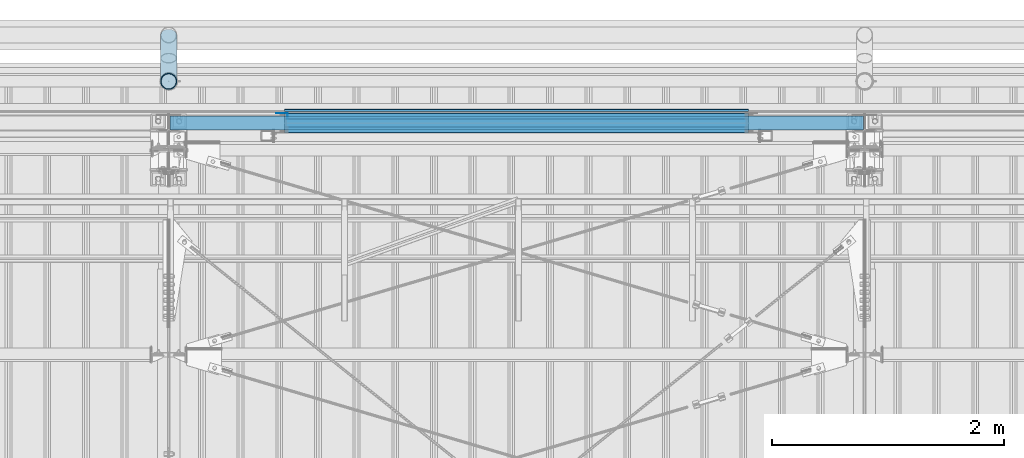
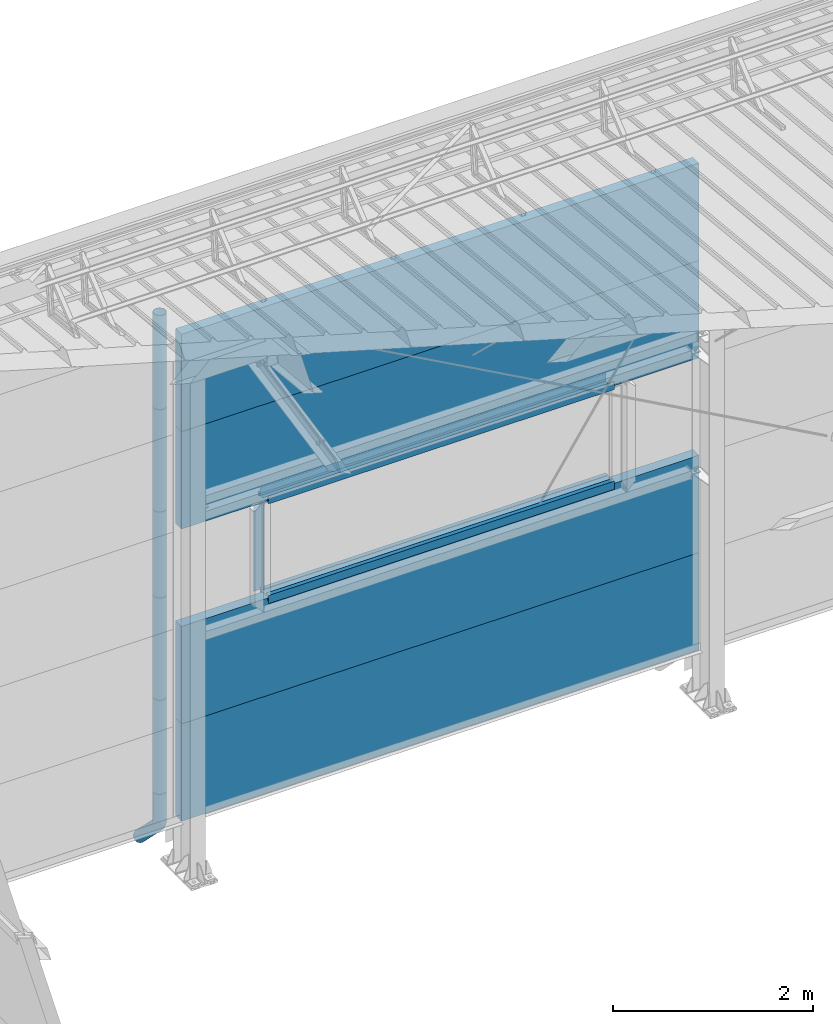
# One storey, part 53 of 709: 18 beams, 18 elements without a shape of their own.
"""IFC4 building model written with IfcOpenShell, lengths in millimetres."""

from ifc_helpers import new_model, entity, si_unit, direction, frame, origin_with_axes, place, context, subcontext, project, spatial, line, indexed_curve, outline, extrude, material, element, aggregate, save


model = new_model("IFC4")

# Units and contexts
model_context = context("Model", 3, precision=0.2, world=origin_with_axes(), true_north=direction((0.0, 1.0)))
body_context = subcontext(model_context, "Body", "Model", "MODEL_VIEW")
ifc_project = project(units=[si_unit("LENGTHUNIT", "METRE", prefix="MILLI"), si_unit("AREAUNIT", "SQUARE_METRE"), si_unit("VOLUMEUNIT", "CUBIC_METRE"), si_unit("MASSUNIT", "GRAM", prefix="KILO"), si_unit("TIMEUNIT", "SECOND"), si_unit("PLANEANGLEUNIT", "RADIAN"), si_unit("SOLIDANGLEUNIT", "STERADIAN"), si_unit("THERMODYNAMICTEMPERATUREUNIT", "DEGREE_CELSIUS"), si_unit("LUMINOUSINTENSITYUNIT", "LUMEN")], contexts=[model_context])

# Site, building, storey
site_placement = place(None, origin_with_axes())
site = spatial("IfcSite", under=ifc_project, at=site_placement, CompositionType="ELEMENT")
building_placement = place(site_placement, origin_with_axes())
building = spatial("IfcBuilding", under=site, at=building_placement, Name="Undefined", CompositionType="ELEMENT")
storey_placement = place(building_placement, origin_with_axes())
storey = spatial("IfcBuildingStorey", under=building, at=storey_placement, Name="Undefined", CompositionType="ELEMENT", Elevation=0.0)

# Assembly, beam
assembly_1_placement = place(storey_placement, frame((4010.0, 22060.0, 895.0), z_axis=(0.0, 0.0, -1.0), x_axis=(1.0, 0.0, 0.0)))
assembly_1 = element("IfcElementAssembly", 1, at=assembly_1_placement, inside=storey)
ifc_material_1 = material(Name="Insulation", Category="Insulation")
beam_1_placement = place(assembly_1_placement, origin_with_axes())
beam_1 = element("IfcBeam", 2, at=beam_1_placement, material=ifc_material_1, ObjectType="P-107", context=body_context, shape_type="SolidModel", body=[
    extrude(outline(indexed_curve([(-595.0, -60.0), (595.0, -60.0), (595.0, 60.0), (-595.0, 60.0)], segments=[line(1, 2, 3, 4, 1)])), frame((0.0, 0.0, 0.0), z_axis=(-1.0, 0.0, 0.0), x_axis=(0.0, 0.0, 1.0)), (0.0, 0.0, -1.0), 5980.0),
])
aggregate(assembly_1, [beam_1])

assembly_2_placement = place(storey_placement, frame((4010.0, 22060.0, 2085.0), z_axis=(0.0, 0.0, -1.0), x_axis=(1.0, 0.0, 0.0)))
assembly_2 = element("IfcElementAssembly", 3, at=assembly_2_placement, inside=storey)
beam_2_placement = place(assembly_2_placement, origin_with_axes())
beam_2 = element("IfcBeam", 4, at=beam_2_placement, material=ifc_material_1, ObjectType="P-107", context=body_context, shape_type="SolidModel", body=[
    extrude(outline(indexed_curve([(-595.0, -60.0), (595.0, -60.0), (595.0, 60.0), (-595.0, 60.0)], segments=[line(1, 2, 3, 4, 1)])), frame((0.0, 0.0, 0.0), z_axis=(-1.0, 0.0, 0.0), x_axis=(0.0, 0.0, 1.0)), (0.0, 0.0, -1.0), 5980.0),
])
aggregate(assembly_2, [beam_2])

assembly_3_placement = place(storey_placement, frame((4010.0, 22060.0, 4465.0), z_axis=(0.0, 0.0, -1.0), x_axis=(1.0, 0.0, 0.0)))
assembly_3 = element("IfcElementAssembly", 5, at=assembly_3_placement, inside=storey)
beam_3_placement = place(assembly_3_placement, origin_with_axes())
beam_3 = element("IfcBeam", 6, at=beam_3_placement, material=ifc_material_1, ObjectType="P-107", context=body_context, shape_type="SolidModel", body=[
    extrude(outline(indexed_curve([(-595.0, -60.0), (595.0, -60.0), (595.0, 60.0), (-595.0, 60.0)], segments=[line(1, 2, 3, 4, 1)])), frame((0.0, 0.0, 0.0), z_axis=(-1.0, 0.0, 0.0), x_axis=(0.0, 0.0, 1.0)), (0.0, 0.0, -1.0), 5980.0),
])
aggregate(assembly_3, [beam_3])

assembly_4_placement = place(storey_placement, frame((4010.0, 22060.0, 5655.0), z_axis=(0.0, 0.0, -1.0), x_axis=(1.0, 0.0, 0.0)))
assembly_4 = element("IfcElementAssembly", 7, at=assembly_4_placement, inside=storey)
beam_4_placement = place(assembly_4_placement, origin_with_axes())
beam_4 = element("IfcBeam", 8, at=beam_4_placement, material=ifc_material_1, ObjectType="P-107", context=body_context, shape_type="SolidModel", body=[
    extrude(outline(indexed_curve([(-595.0, -60.0), (595.0, -60.0), (595.0, 60.0), (-595.0, 60.0)], segments=[line(1, 2, 3, 4, 1)])), frame((0.0, 0.0, 0.0), z_axis=(-1.0, 0.0, 0.0), x_axis=(0.0, 0.0, 1.0)), (0.0, 0.0, -1.0), 5980.0),
])
aggregate(assembly_4, [beam_4])

assembly_5_placement = place(storey_placement, frame((9000.0, 22001.0, 2725.0), z_axis=(0.0, -1.0, 0.0), x_axis=(-1.0, 0.0, 0.0)))
assembly_5 = element("IfcElementAssembly", 9, at=assembly_5_placement, inside=storey)
ifc_material_2 = material(Name="Steel_Undefined", Category="STEEL")
beam_5_placement = place(assembly_5_placement, origin_with_axes())
beam_5 = element("IfcBeam", 10, at=beam_5_placement, material=ifc_material_2, context=body_context, shape_type="SolidModel", body=[
    extrude(outline(indexed_curve([(-25.0, -1.0), (25.0, -1.0), (25.0, 99.0), (23.0, 99.0), (23.0, 1.0), (-25.0, 1.0)], segments=[line(1, 2, 3, 4, 5, 6, 1)])), frame((0.0, 0.0, 0.0), z_axis=(-1.0, 0.0, 0.0), x_axis=(0.0, 0.0, 1.0)), (0.0, 0.0, -1.0), 4000.0),
])
aggregate(assembly_5, [beam_5])

assembly_6_placement = place(storey_placement, frame((9000.0, 22060.0, 2680.0), z_axis=(0.0, 1.0, 0.0), x_axis=(-1.0, 0.0, 0.0)))
assembly_6 = element("IfcElementAssembly", 11, at=assembly_6_placement, inside=storey)
beam_6_placement = place(assembly_6_placement, origin_with_axes())
beam_6 = element("IfcBeam", 12, at=beam_6_placement, material=ifc_material_2, context=body_context, shape_type="SolidModel", body=[
    extrude(outline(indexed_curve([(-70.0, -25.0), (-68.0, -25.0), (-68.0, 23.0), (68.0, 23.0), (68.0, -25.0), (70.0, -25.0), (70.0, 25.0), (-70.0, 25.0)], segments=[line(1, 2, 3, 4, 5, 6, 7, 8, 1)])), frame((0.0, 0.0, 0.0), z_axis=(-1.0, 0.0, 0.0), x_axis=(0.0, 0.0, 1.0)), (0.0, 0.0, -1.0), 4000.0),
])
aggregate(assembly_6, [beam_6])

assembly_7_placement = place(storey_placement, frame((5000.0, 22121.0, 2725.0), z_axis=(0.0, 1.0, 0.0), x_axis=(1.0, 0.0, 0.0)))
assembly_7 = element("IfcElementAssembly", 13, at=assembly_7_placement, inside=storey)
beam_7_placement = place(assembly_7_placement, origin_with_axes())
beam_7 = element("IfcBeam", 14, at=beam_7_placement, material=ifc_material_2, context=body_context, shape_type="SolidModel", body=[
    extrude(outline(indexed_curve([(-25.0, -1.0), (25.0, -1.0), (25.0, 99.0), (23.0, 99.0), (23.0, 1.0), (-25.0, 1.0)], segments=[line(1, 2, 3, 4, 5, 6, 1)])), frame((0.0, 0.0, 0.0), z_axis=(-1.0, 0.0, 0.0), x_axis=(0.0, 0.0, 1.0)), (0.0, 0.0, -1.0), 4000.0),
])
aggregate(assembly_7, [beam_7])

assembly_8_placement = place(storey_placement, frame((5000.0, 22001.0, 3845.0), z_axis=(0.0, -1.0, 0.0), x_axis=(1.0, 0.0, 0.0)))
assembly_8 = element("IfcElementAssembly", 15, at=assembly_8_placement, inside=storey)
beam_8_placement = place(assembly_8_placement, origin_with_axes())
beam_8 = element("IfcBeam", 16, at=beam_8_placement, material=ifc_material_2, context=body_context, shape_type="SolidModel", body=[
    extrude(outline(indexed_curve([(-25.0, -1.0), (25.0, -1.0), (25.0, 99.0), (23.0, 99.0), (23.0, 1.0), (-25.0, 1.0)], segments=[line(1, 2, 3, 4, 5, 6, 1)])), frame((0.0, 0.0, 0.0), z_axis=(-1.0, 0.0, 0.0), x_axis=(0.0, 0.0, 1.0)), (0.0, 0.0, -1.0), 4000.0),
])
aggregate(assembly_8, [beam_8])

assembly_9_placement = place(storey_placement, frame((9000.0, 22060.0, 3890.0), z_axis=(0.0, -1.0, 0.0), x_axis=(-1.0, 0.0, 0.0)))
assembly_9 = element("IfcElementAssembly", 17, at=assembly_9_placement, inside=storey)
beam_9_placement = place(assembly_9_placement, origin_with_axes())
beam_9 = element("IfcBeam", 18, at=beam_9_placement, material=ifc_material_2, context=body_context, shape_type="SolidModel", body=[
    extrude(outline(indexed_curve([(-70.0, -25.0), (-68.0, -25.0), (-68.0, 23.0), (68.0, 23.0), (68.0, -25.0), (70.0, -25.0), (70.0, 25.0), (-70.0, 25.0)], segments=[line(1, 2, 3, 4, 5, 6, 7, 8, 1)])), frame((0.0, 0.0, 0.0), z_axis=(-1.0, 0.0, 0.0), x_axis=(0.0, 0.0, 1.0)), (0.0, 0.0, -1.0), 4000.0),
])
aggregate(assembly_9, [beam_9])

assembly_10_placement = place(storey_placement, frame((9000.0, 22121.0, 3845.0), z_axis=(0.0, 1.0, 0.0), x_axis=(-1.0, 0.0, 0.0)))
assembly_10 = element("IfcElementAssembly", 19, at=assembly_10_placement, inside=storey)
beam_10_placement = place(assembly_10_placement, origin_with_axes())
beam_10 = element("IfcBeam", 20, at=beam_10_placement, material=ifc_material_2, context=body_context, shape_type="SolidModel", body=[
    extrude(outline(indexed_curve([(-25.0, -1.0), (25.0, -1.0), (25.0, 99.0), (23.0, 99.0), (23.0, 1.0), (-25.0, 1.0)], segments=[line(1, 2, 3, 4, 5, 6, 1)])), frame((0.0, 0.0, 0.0), z_axis=(-1.0, 0.0, 0.0), x_axis=(0.0, 0.0, 1.0)), (0.0, 0.0, -1.0), 4000.0),
])
aggregate(assembly_10, [beam_10])

assembly_11_placement = place(storey_placement, frame((9000.0, 22171.0, 3830.0), z_axis=(0.0, 1.0, 0.0), x_axis=(-1.0, 0.0, 0.0)))
assembly_11 = element("IfcElementAssembly", 21, at=assembly_11_placement, inside=storey)
beam_11_placement = place(assembly_11_placement, origin_with_axes())
beam_11 = element("IfcBeam", 22, at=beam_11_placement, material=ifc_material_2, context=body_context, shape_type="SolidModel", body=[
    extrude(outline(indexed_curve([(-10.0, -1.0), (10.0, -1.0), (10.0, 49.0), (8.0, 49.0), (8.0, 1.0), (-10.0, 1.0)], segments=[line(1, 2, 3, 4, 5, 6, 1)])), frame((0.0, 0.0, 0.0), z_axis=(-1.0, 0.0, 0.0), x_axis=(0.0, 0.0, 1.0)), (0.0, 0.0, -1.0), 4000.0),
])
aggregate(assembly_11, [beam_11])

assembly_12_placement = place(storey_placement, frame((5025.0, 22121.0, 3870.0), z_axis=(0.0, 1.0, 0.0), x_axis=(0.0, 0.0, -1.0)))
assembly_12 = element("IfcElementAssembly", 23, at=assembly_12_placement, inside=storey)
beam_12_placement = place(assembly_12_placement, origin_with_axes())
beam_12 = element("IfcBeam", 24, at=beam_12_placement, material=ifc_material_2, context=body_context, shape_type="SolidModel", body=[
    extrude(outline(indexed_curve([(-25.0, -1.0), (25.0, -1.0), (25.0, 99.0), (23.0, 99.0), (23.0, 1.0), (-25.0, 1.0)], segments=[line(1, 2, 3, 4, 5, 6, 1)])), frame((0.0, 0.0, 0.0), z_axis=(-1.0, 0.0, 0.0), x_axis=(0.0, 0.0, 1.0)), (0.0, 0.0, -1.0), 1170.0),
])
aggregate(assembly_12, [beam_12])

assembly_13_placement = place(storey_placement, frame((4000.0, 22420.0, 6276.92297), z_axis=(0.0, -1.0, 0.0), x_axis=(0.0, 0.0, -1.0)))
assembly_13 = element("IfcElementAssembly", 25, at=assembly_13_placement, inside=storey)
beam_13_placement = place(assembly_13_placement, origin_with_axes())
beam_13 = element("IfcBeam", 26, at=beam_13_placement, material=ifc_material_2, ObjectType="614", context=body_context, shape_type="SolidModel", body=[
    extrude(outline(indexed_curve([(70.0, 0.0), (69.61653, 7.31699), (68.47033, 14.55382), (66.57396, 21.63119), (63.94818, 28.47157), (60.62178, 35.0), (56.63119, 41.14497), (52.02014, 46.83914), (46.83914, 52.02014), (41.14497, 56.63119), (35.0, 60.62178), (28.47157, 63.94818), (21.63119, 66.57396), (14.55382, 68.47033), (7.31699, 69.61653), (0.0, 70.0), (-7.31699, 69.61653), (-14.55382, 68.47033), (-21.63119, 66.57396), (-28.47157, 63.94818), (-35.0, 60.62178), (-41.14497, 56.63119), (-46.83914, 52.02014), (-52.02014, 46.83914), (-56.63119, 41.14497), (-60.62178, 35.0), (-63.94818, 28.47157), (-66.57396, 21.63119), (-68.47033, 14.55382), (-69.61653, 7.31699), (-70.0, 0.0), (-69.61653, -7.31699), (-68.47033, -14.55382), (-66.57396, -21.63119), (-63.94818, -28.47157), (-60.62178, -35.0), (-56.63119, -41.14497), (-52.02014, -46.83914), (-46.83914, -52.02014), (-41.14497, -56.63119), (-35.0, -60.62178), (-28.47157, -63.94818), (-21.63119, -66.57396), (-14.55382, -68.47033), (-7.31699, -69.61653), (0.0, -70.0), (7.31699, -69.61653), (14.55382, -68.47033), (21.63119, -66.57396), (28.47157, -63.94818), (35.0, -60.62178), (41.14497, -56.63119), (46.83914, -52.02014), (52.02014, -46.83914), (56.63119, -41.14497), (60.62178, -35.0), (63.94818, -28.47157), (66.57396, -21.63119), (68.47033, -14.55382), (69.61653, -7.31699)], segments=[line(1, 2, 3, 4, 5, 6, 7, 8, 9, 10, 11, 12, 13, 14, 15, 16, 17, 18, 19, 20, 21, 22, 23, 24, 25, 26, 27, 28, 29, 30, 31, 32, 33, 34, 35, 36, 37, 38, 39, 40, 41, 42, 43, 44, 45, 46, 47, 48, 49, 50, 51, 52, 53, 54, 55, 56, 57, 58, 59, 60, 1)]), holes=[indexed_curve([(65.0, 0.0), (64.64392, -6.79435), (63.57959, -13.51426), (61.81867, -20.0861), (59.38045, -26.43788), (56.29165, -32.5), (52.5861, -38.20604), (48.30441, -43.49349), (43.49349, -48.30441), (38.20604, -52.5861), (32.5, -56.29165), (26.43788, -59.38045), (20.0861, -61.81867), (13.51426, -63.57959), (6.79435, -64.64392), (0.0, -65.0), (-6.79435, -64.64392), (-13.51426, -63.57959), (-20.0861, -61.81867), (-26.43788, -59.38045), (-32.5, -56.29165), (-38.20604, -52.5861), (-43.49349, -48.30441), (-48.30441, -43.49349), (-52.5861, -38.20604), (-56.29165, -32.5), (-59.38045, -26.43788), (-61.81867, -20.0861), (-63.57959, -13.51426), (-64.64392, -6.79435), (-65.0, 0.0), (-64.64392, 6.79435), (-63.57959, 13.51426), (-61.81867, 20.0861), (-59.38045, 26.43788), (-56.29165, 32.5), (-52.5861, 38.20604), (-48.30441, 43.49349), (-43.49349, 48.30441), (-38.20604, 52.5861), (-32.5, 56.29165), (-26.43788, 59.38045), (-20.0861, 61.81867), (-13.51426, 63.57959), (-6.79435, 64.64392), (0.0, 65.0), (6.79435, 64.64392), (13.51426, 63.57959), (20.0861, 61.81867), (26.43788, 59.38045), (32.5, 56.29165), (38.20604, 52.5861), (43.49349, 48.30441), (48.30441, 43.49349), (52.5861, 38.20604), (56.29165, 32.5), (59.38045, 26.43788), (61.81867, 20.0861), (63.57959, 13.51426), (64.64392, 6.79435)], segments=[line(1, 2, 3, 4, 5, 6, 7, 8, 9, 10, 11, 12, 13, 14, 15, 16, 17, 18, 19, 20, 21, 22, 23, 24, 25, 26, 27, 28, 29, 30, 31, 32, 33, 34, 35, 36, 37, 38, 39, 40, 41, 42, 43, 44, 45, 46, 47, 48, 49, 50, 51, 52, 53, 54, 55, 56, 57, 58, 59, 60, 1)])]), frame((0.0, 0.0, 0.0), z_axis=(-1.0, 0.0, 0.0), x_axis=(0.0, 0.0, 1.0)), (0.0, 0.0, -1.0), 1250.0),
])
aggregate(assembly_13, [beam_13])

assembly_14_placement = place(storey_placement, frame((4000.0, 22420.0, 5126.92297), z_axis=(0.0, -1.0, 0.0), x_axis=(0.0, 0.0, -1.0)))
assembly_14 = element("IfcElementAssembly", 27, at=assembly_14_placement, inside=storey)
beam_14_placement = place(assembly_14_placement, origin_with_axes())
beam_14 = element("IfcBeam", 28, at=beam_14_placement, material=ifc_material_2, ObjectType="614", context=body_context, shape_type="SolidModel", body=[
    extrude(outline(indexed_curve([(70.0, 0.0), (69.61653, 7.31699), (68.47033, 14.55382), (66.57396, 21.63119), (63.94818, 28.47157), (60.62178, 35.0), (56.63119, 41.14497), (52.02014, 46.83914), (46.83914, 52.02014), (41.14497, 56.63119), (35.0, 60.62178), (28.47157, 63.94818), (21.63119, 66.57396), (14.55382, 68.47033), (7.31699, 69.61653), (0.0, 70.0), (-7.31699, 69.61653), (-14.55382, 68.47033), (-21.63119, 66.57396), (-28.47157, 63.94818), (-35.0, 60.62178), (-41.14497, 56.63119), (-46.83914, 52.02014), (-52.02014, 46.83914), (-56.63119, 41.14497), (-60.62178, 35.0), (-63.94818, 28.47157), (-66.57396, 21.63119), (-68.47033, 14.55382), (-69.61653, 7.31699), (-70.0, 0.0), (-69.61653, -7.31699), (-68.47033, -14.55382), (-66.57396, -21.63119), (-63.94818, -28.47157), (-60.62178, -35.0), (-56.63119, -41.14497), (-52.02014, -46.83914), (-46.83914, -52.02014), (-41.14497, -56.63119), (-35.0, -60.62178), (-28.47157, -63.94818), (-21.63119, -66.57396), (-14.55382, -68.47033), (-7.31699, -69.61653), (0.0, -70.0), (7.31699, -69.61653), (14.55382, -68.47033), (21.63119, -66.57396), (28.47157, -63.94818), (35.0, -60.62178), (41.14497, -56.63119), (46.83914, -52.02014), (52.02014, -46.83914), (56.63119, -41.14497), (60.62178, -35.0), (63.94818, -28.47157), (66.57396, -21.63119), (68.47033, -14.55382), (69.61653, -7.31699)], segments=[line(1, 2, 3, 4, 5, 6, 7, 8, 9, 10, 11, 12, 13, 14, 15, 16, 17, 18, 19, 20, 21, 22, 23, 24, 25, 26, 27, 28, 29, 30, 31, 32, 33, 34, 35, 36, 37, 38, 39, 40, 41, 42, 43, 44, 45, 46, 47, 48, 49, 50, 51, 52, 53, 54, 55, 56, 57, 58, 59, 60, 1)]), holes=[indexed_curve([(65.0, 0.0), (64.64392, -6.79435), (63.57959, -13.51426), (61.81867, -20.0861), (59.38045, -26.43788), (56.29165, -32.5), (52.5861, -38.20604), (48.30441, -43.49349), (43.49349, -48.30441), (38.20604, -52.5861), (32.5, -56.29165), (26.43788, -59.38045), (20.0861, -61.81867), (13.51426, -63.57959), (6.79435, -64.64392), (0.0, -65.0), (-6.79435, -64.64392), (-13.51426, -63.57959), (-20.0861, -61.81867), (-26.43788, -59.38045), (-32.5, -56.29165), (-38.20604, -52.5861), (-43.49349, -48.30441), (-48.30441, -43.49349), (-52.5861, -38.20604), (-56.29165, -32.5), (-59.38045, -26.43788), (-61.81867, -20.0861), (-63.57959, -13.51426), (-64.64392, -6.79435), (-65.0, 0.0), (-64.64392, 6.79435), (-63.57959, 13.51426), (-61.81867, 20.0861), (-59.38045, 26.43788), (-56.29165, 32.5), (-52.5861, 38.20604), (-48.30441, 43.49349), (-43.49349, 48.30441), (-38.20604, 52.5861), (-32.5, 56.29165), (-26.43788, 59.38045), (-20.0861, 61.81867), (-13.51426, 63.57959), (-6.79435, 64.64392), (0.0, 65.0), (6.79435, 64.64392), (13.51426, 63.57959), (20.0861, 61.81867), (26.43788, 59.38045), (32.5, 56.29165), (38.20604, 52.5861), (43.49349, 48.30441), (48.30441, 43.49349), (52.5861, 38.20604), (56.29165, 32.5), (59.38045, 26.43788), (61.81867, 20.0861), (63.57959, 13.51426), (64.64392, 6.79435)], segments=[line(1, 2, 3, 4, 5, 6, 7, 8, 9, 10, 11, 12, 13, 14, 15, 16, 17, 18, 19, 20, 21, 22, 23, 24, 25, 26, 27, 28, 29, 30, 31, 32, 33, 34, 35, 36, 37, 38, 39, 40, 41, 42, 43, 44, 45, 46, 47, 48, 49, 50, 51, 52, 53, 54, 55, 56, 57, 58, 59, 60, 1)])]), frame((0.0, 0.0, 0.0), z_axis=(-1.0, 0.0, 0.0), x_axis=(0.0, 0.0, 1.0)), (0.0, 0.0, -1.0), 1250.0),
])
aggregate(assembly_14, [beam_14])

assembly_15_placement = place(storey_placement, frame((4000.0, 22420.0, 3976.92297), z_axis=(0.0, -1.0, 0.0), x_axis=(0.0, 0.0, -1.0)))
assembly_15 = element("IfcElementAssembly", 29, at=assembly_15_placement, inside=storey)
beam_15_placement = place(assembly_15_placement, origin_with_axes())
beam_15 = element("IfcBeam", 30, at=beam_15_placement, material=ifc_material_2, ObjectType="614", context=body_context, shape_type="SolidModel", body=[
    extrude(outline(indexed_curve([(70.0, 0.0), (69.61653, 7.31699), (68.47033, 14.55382), (66.57396, 21.63119), (63.94818, 28.47157), (60.62178, 35.0), (56.63119, 41.14497), (52.02014, 46.83914), (46.83914, 52.02014), (41.14497, 56.63119), (35.0, 60.62178), (28.47157, 63.94818), (21.63119, 66.57396), (14.55382, 68.47033), (7.31699, 69.61653), (0.0, 70.0), (-7.31699, 69.61653), (-14.55382, 68.47033), (-21.63119, 66.57396), (-28.47157, 63.94818), (-35.0, 60.62178), (-41.14497, 56.63119), (-46.83914, 52.02014), (-52.02014, 46.83914), (-56.63119, 41.14497), (-60.62178, 35.0), (-63.94818, 28.47157), (-66.57396, 21.63119), (-68.47033, 14.55382), (-69.61653, 7.31699), (-70.0, 0.0), (-69.61653, -7.31699), (-68.47033, -14.55382), (-66.57396, -21.63119), (-63.94818, -28.47157), (-60.62178, -35.0), (-56.63119, -41.14497), (-52.02014, -46.83914), (-46.83914, -52.02014), (-41.14497, -56.63119), (-35.0, -60.62178), (-28.47157, -63.94818), (-21.63119, -66.57396), (-14.55382, -68.47033), (-7.31699, -69.61653), (0.0, -70.0), (7.31699, -69.61653), (14.55382, -68.47033), (21.63119, -66.57396), (28.47157, -63.94818), (35.0, -60.62178), (41.14497, -56.63119), (46.83914, -52.02014), (52.02014, -46.83914), (56.63119, -41.14497), (60.62178, -35.0), (63.94818, -28.47157), (66.57396, -21.63119), (68.47033, -14.55382), (69.61653, -7.31699)], segments=[line(1, 2, 3, 4, 5, 6, 7, 8, 9, 10, 11, 12, 13, 14, 15, 16, 17, 18, 19, 20, 21, 22, 23, 24, 25, 26, 27, 28, 29, 30, 31, 32, 33, 34, 35, 36, 37, 38, 39, 40, 41, 42, 43, 44, 45, 46, 47, 48, 49, 50, 51, 52, 53, 54, 55, 56, 57, 58, 59, 60, 1)]), holes=[indexed_curve([(65.0, 0.0), (64.64392, -6.79435), (63.57959, -13.51426), (61.81867, -20.0861), (59.38045, -26.43788), (56.29165, -32.5), (52.5861, -38.20604), (48.30441, -43.49349), (43.49349, -48.30441), (38.20604, -52.5861), (32.5, -56.29165), (26.43788, -59.38045), (20.0861, -61.81867), (13.51426, -63.57959), (6.79435, -64.64392), (0.0, -65.0), (-6.79435, -64.64392), (-13.51426, -63.57959), (-20.0861, -61.81867), (-26.43788, -59.38045), (-32.5, -56.29165), (-38.20604, -52.5861), (-43.49349, -48.30441), (-48.30441, -43.49349), (-52.5861, -38.20604), (-56.29165, -32.5), (-59.38045, -26.43788), (-61.81867, -20.0861), (-63.57959, -13.51426), (-64.64392, -6.79435), (-65.0, 0.0), (-64.64392, 6.79435), (-63.57959, 13.51426), (-61.81867, 20.0861), (-59.38045, 26.43788), (-56.29165, 32.5), (-52.5861, 38.20604), (-48.30441, 43.49349), (-43.49349, 48.30441), (-38.20604, 52.5861), (-32.5, 56.29165), (-26.43788, 59.38045), (-20.0861, 61.81867), (-13.51426, 63.57959), (-6.79435, 64.64392), (0.0, 65.0), (6.79435, 64.64392), (13.51426, 63.57959), (20.0861, 61.81867), (26.43788, 59.38045), (32.5, 56.29165), (38.20604, 52.5861), (43.49349, 48.30441), (48.30441, 43.49349), (52.5861, 38.20604), (56.29165, 32.5), (59.38045, 26.43788), (61.81867, 20.0861), (63.57959, 13.51426), (64.64392, 6.79435)], segments=[line(1, 2, 3, 4, 5, 6, 7, 8, 9, 10, 11, 12, 13, 14, 15, 16, 17, 18, 19, 20, 21, 22, 23, 24, 25, 26, 27, 28, 29, 30, 31, 32, 33, 34, 35, 36, 37, 38, 39, 40, 41, 42, 43, 44, 45, 46, 47, 48, 49, 50, 51, 52, 53, 54, 55, 56, 57, 58, 59, 60, 1)])]), frame((0.0, 0.0, 0.0), z_axis=(-1.0, 0.0, 0.0), x_axis=(0.0, 0.0, 1.0)), (0.0, 0.0, -1.0), 1250.0),
])
aggregate(assembly_15, [beam_15])

assembly_16_placement = place(storey_placement, frame((4000.0, 22420.0, 2826.92297), z_axis=(0.0, -1.0, 0.0), x_axis=(0.0, 0.0, -1.0)))
assembly_16 = element("IfcElementAssembly", 31, at=assembly_16_placement, inside=storey)
beam_16_placement = place(assembly_16_placement, origin_with_axes())
beam_16 = element("IfcBeam", 32, at=beam_16_placement, material=ifc_material_2, ObjectType="614", context=body_context, shape_type="SolidModel", body=[
    extrude(outline(indexed_curve([(70.0, 0.0), (69.61653, 7.31699), (68.47033, 14.55382), (66.57396, 21.63119), (63.94818, 28.47157), (60.62178, 35.0), (56.63119, 41.14497), (52.02014, 46.83914), (46.83914, 52.02014), (41.14497, 56.63119), (35.0, 60.62178), (28.47157, 63.94818), (21.63119, 66.57396), (14.55382, 68.47033), (7.31699, 69.61653), (0.0, 70.0), (-7.31699, 69.61653), (-14.55382, 68.47033), (-21.63119, 66.57396), (-28.47157, 63.94818), (-35.0, 60.62178), (-41.14497, 56.63119), (-46.83914, 52.02014), (-52.02014, 46.83914), (-56.63119, 41.14497), (-60.62178, 35.0), (-63.94818, 28.47157), (-66.57396, 21.63119), (-68.47033, 14.55382), (-69.61653, 7.31699), (-70.0, 0.0), (-69.61653, -7.31699), (-68.47033, -14.55382), (-66.57396, -21.63119), (-63.94818, -28.47157), (-60.62178, -35.0), (-56.63119, -41.14497), (-52.02014, -46.83914), (-46.83914, -52.02014), (-41.14497, -56.63119), (-35.0, -60.62178), (-28.47157, -63.94818), (-21.63119, -66.57396), (-14.55382, -68.47033), (-7.31699, -69.61653), (0.0, -70.0), (7.31699, -69.61653), (14.55382, -68.47033), (21.63119, -66.57396), (28.47157, -63.94818), (35.0, -60.62178), (41.14497, -56.63119), (46.83914, -52.02014), (52.02014, -46.83914), (56.63119, -41.14497), (60.62178, -35.0), (63.94818, -28.47157), (66.57396, -21.63119), (68.47033, -14.55382), (69.61653, -7.31699)], segments=[line(1, 2, 3, 4, 5, 6, 7, 8, 9, 10, 11, 12, 13, 14, 15, 16, 17, 18, 19, 20, 21, 22, 23, 24, 25, 26, 27, 28, 29, 30, 31, 32, 33, 34, 35, 36, 37, 38, 39, 40, 41, 42, 43, 44, 45, 46, 47, 48, 49, 50, 51, 52, 53, 54, 55, 56, 57, 58, 59, 60, 1)]), holes=[indexed_curve([(65.0, 0.0), (64.64392, -6.79435), (63.57959, -13.51426), (61.81867, -20.0861), (59.38045, -26.43788), (56.29165, -32.5), (52.5861, -38.20604), (48.30441, -43.49349), (43.49349, -48.30441), (38.20604, -52.5861), (32.5, -56.29165), (26.43788, -59.38045), (20.0861, -61.81867), (13.51426, -63.57959), (6.79435, -64.64392), (0.0, -65.0), (-6.79435, -64.64392), (-13.51426, -63.57959), (-20.0861, -61.81867), (-26.43788, -59.38045), (-32.5, -56.29165), (-38.20604, -52.5861), (-43.49349, -48.30441), (-48.30441, -43.49349), (-52.5861, -38.20604), (-56.29165, -32.5), (-59.38045, -26.43788), (-61.81867, -20.0861), (-63.57959, -13.51426), (-64.64392, -6.79435), (-65.0, 0.0), (-64.64392, 6.79435), (-63.57959, 13.51426), (-61.81867, 20.0861), (-59.38045, 26.43788), (-56.29165, 32.5), (-52.5861, 38.20604), (-48.30441, 43.49349), (-43.49349, 48.30441), (-38.20604, 52.5861), (-32.5, 56.29165), (-26.43788, 59.38045), (-20.0861, 61.81867), (-13.51426, 63.57959), (-6.79435, 64.64392), (0.0, 65.0), (6.79435, 64.64392), (13.51426, 63.57959), (20.0861, 61.81867), (26.43788, 59.38045), (32.5, 56.29165), (38.20604, 52.5861), (43.49349, 48.30441), (48.30441, 43.49349), (52.5861, 38.20604), (56.29165, 32.5), (59.38045, 26.43788), (61.81867, 20.0861), (63.57959, 13.51426), (64.64392, 6.79435)], segments=[line(1, 2, 3, 4, 5, 6, 7, 8, 9, 10, 11, 12, 13, 14, 15, 16, 17, 18, 19, 20, 21, 22, 23, 24, 25, 26, 27, 28, 29, 30, 31, 32, 33, 34, 35, 36, 37, 38, 39, 40, 41, 42, 43, 44, 45, 46, 47, 48, 49, 50, 51, 52, 53, 54, 55, 56, 57, 58, 59, 60, 1)])]), frame((0.0, 0.0, 0.0), z_axis=(-1.0, 0.0, 0.0), x_axis=(0.0, 0.0, 1.0)), (0.0, 0.0, -1.0), 1250.0),
])
aggregate(assembly_16, [beam_16])

assembly_17_placement = place(storey_placement, frame((4000.0, 22420.0, 1676.92297), z_axis=(0.0, -1.0, 0.0), x_axis=(0.0, 0.0, -1.0)))
assembly_17 = element("IfcElementAssembly", 33, at=assembly_17_placement, inside=storey)
beam_17_placement = place(assembly_17_placement, origin_with_axes())
beam_17 = element("IfcBeam", 34, at=beam_17_placement, material=ifc_material_2, ObjectType="614", context=body_context, shape_type="SolidModel", body=[
    extrude(outline(indexed_curve([(70.0, 0.0), (69.61653, 7.31699), (68.47033, 14.55382), (66.57396, 21.63119), (63.94818, 28.47157), (60.62178, 35.0), (56.63119, 41.14497), (52.02014, 46.83914), (46.83914, 52.02014), (41.14497, 56.63119), (35.0, 60.62178), (28.47157, 63.94818), (21.63119, 66.57396), (14.55382, 68.47033), (7.31699, 69.61653), (0.0, 70.0), (-7.31699, 69.61653), (-14.55382, 68.47033), (-21.63119, 66.57396), (-28.47157, 63.94818), (-35.0, 60.62178), (-41.14497, 56.63119), (-46.83914, 52.02014), (-52.02014, 46.83914), (-56.63119, 41.14497), (-60.62178, 35.0), (-63.94818, 28.47157), (-66.57396, 21.63119), (-68.47033, 14.55382), (-69.61653, 7.31699), (-70.0, 0.0), (-69.61653, -7.31699), (-68.47033, -14.55382), (-66.57396, -21.63119), (-63.94818, -28.47157), (-60.62178, -35.0), (-56.63119, -41.14497), (-52.02014, -46.83914), (-46.83914, -52.02014), (-41.14497, -56.63119), (-35.0, -60.62178), (-28.47157, -63.94818), (-21.63119, -66.57396), (-14.55382, -68.47033), (-7.31699, -69.61653), (0.0, -70.0), (7.31699, -69.61653), (14.55382, -68.47033), (21.63119, -66.57396), (28.47157, -63.94818), (35.0, -60.62178), (41.14497, -56.63119), (46.83914, -52.02014), (52.02014, -46.83914), (56.63119, -41.14497), (60.62178, -35.0), (63.94818, -28.47157), (66.57396, -21.63119), (68.47033, -14.55382), (69.61653, -7.31699)], segments=[line(1, 2, 3, 4, 5, 6, 7, 8, 9, 10, 11, 12, 13, 14, 15, 16, 17, 18, 19, 20, 21, 22, 23, 24, 25, 26, 27, 28, 29, 30, 31, 32, 33, 34, 35, 36, 37, 38, 39, 40, 41, 42, 43, 44, 45, 46, 47, 48, 49, 50, 51, 52, 53, 54, 55, 56, 57, 58, 59, 60, 1)]), holes=[indexed_curve([(65.0, 0.0), (64.64392, -6.79435), (63.57959, -13.51426), (61.81867, -20.0861), (59.38045, -26.43788), (56.29165, -32.5), (52.5861, -38.20604), (48.30441, -43.49349), (43.49349, -48.30441), (38.20604, -52.5861), (32.5, -56.29165), (26.43788, -59.38045), (20.0861, -61.81867), (13.51426, -63.57959), (6.79435, -64.64392), (0.0, -65.0), (-6.79435, -64.64392), (-13.51426, -63.57959), (-20.0861, -61.81867), (-26.43788, -59.38045), (-32.5, -56.29165), (-38.20604, -52.5861), (-43.49349, -48.30441), (-48.30441, -43.49349), (-52.5861, -38.20604), (-56.29165, -32.5), (-59.38045, -26.43788), (-61.81867, -20.0861), (-63.57959, -13.51426), (-64.64392, -6.79435), (-65.0, 0.0), (-64.64392, 6.79435), (-63.57959, 13.51426), (-61.81867, 20.0861), (-59.38045, 26.43788), (-56.29165, 32.5), (-52.5861, 38.20604), (-48.30441, 43.49349), (-43.49349, 48.30441), (-38.20604, 52.5861), (-32.5, 56.29165), (-26.43788, 59.38045), (-20.0861, 61.81867), (-13.51426, 63.57959), (-6.79435, 64.64392), (0.0, 65.0), (6.79435, 64.64392), (13.51426, 63.57959), (20.0861, 61.81867), (26.43788, 59.38045), (32.5, 56.29165), (38.20604, 52.5861), (43.49349, 48.30441), (48.30441, 43.49349), (52.5861, 38.20604), (56.29165, 32.5), (59.38045, 26.43788), (61.81867, 20.0861), (63.57959, 13.51426), (64.64392, 6.79435)], segments=[line(1, 2, 3, 4, 5, 6, 7, 8, 9, 10, 11, 12, 13, 14, 15, 16, 17, 18, 19, 20, 21, 22, 23, 24, 25, 26, 27, 28, 29, 30, 31, 32, 33, 34, 35, 36, 37, 38, 39, 40, 41, 42, 43, 44, 45, 46, 47, 48, 49, 50, 51, 52, 53, 54, 55, 56, 57, 58, 59, 60, 1)])]), frame((0.0, 0.0, 0.0), z_axis=(-1.0, 0.0, 0.0), x_axis=(0.0, 0.0, 1.0)), (0.0, 0.0, -1.0), 1250.0),
])
aggregate(assembly_17, [beam_17])

assembly_18_placement = place(storey_placement, frame((4000.0, 22420.0, 526.92297), z_axis=(1.0, 0.0, 0.0), x_axis=(0.0, 0.0, -1.0)))
assembly_18 = element("IfcElementAssembly", 35, at=assembly_18_placement, inside=storey)
beam_18_placement = place(assembly_18_placement, origin_with_axes())
beam_18 = element("IfcBeam", 36, at=beam_18_placement, material=ifc_material_2, ObjectType="617", context=body_context, shape_type="SolidModel", body=[
    entity("IfcSweptDiskSolid", entity("IfcIndexedPolyCurve", entity("IfcCartesianPointList3D", [[0.0, 0.0, 0.0], [448.2233, 0.0, 0.0], [496.05873, 9.51506, 0.0], [536.61165, 36.61165, 0.0], [900.0, 400.0, 0.0]]), [entity("IfcLineIndex", [1, 2]), entity("IfcArcIndex", [2, 3, 4]), entity("IfcLineIndex", [4, 5])]), 70.0, 65.0),
])
aggregate(assembly_18, [beam_18])

save(model, "model.ifc")
